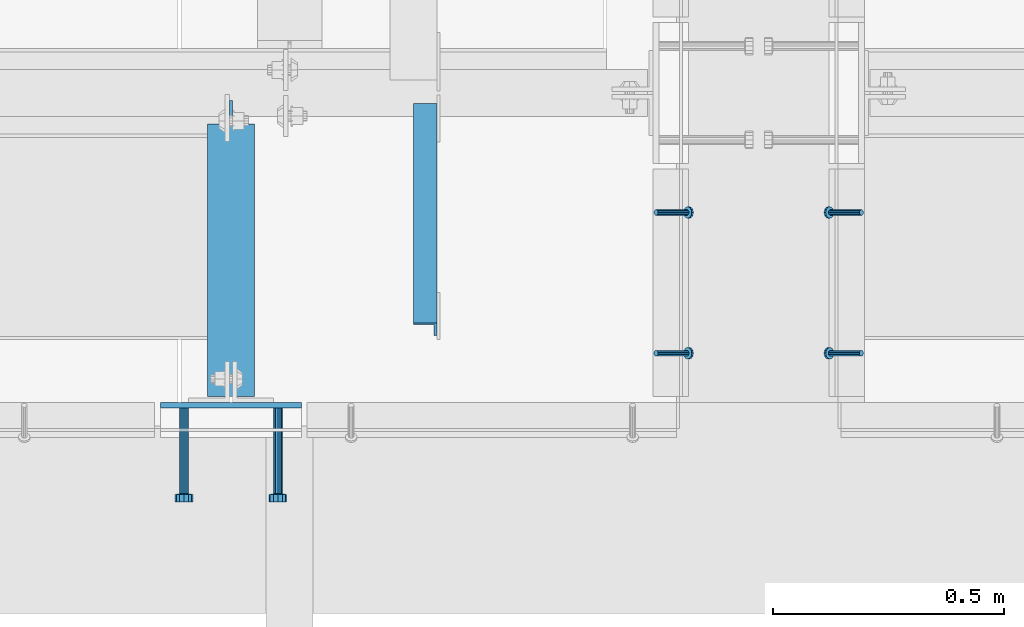
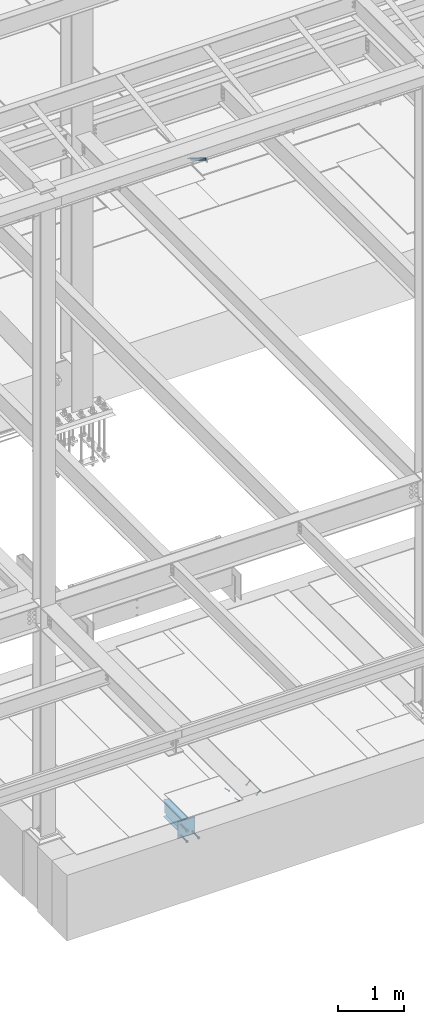
# One storey, part 2046 of 3843: 5 beams, 5 members, 5 elements without a shape of their own.
"""IFC2X3 building model written with IfcOpenShell, lengths in millimetres."""

from ifc_helpers import new_model, si_unit, frame, origin_with_axes, place, context, subcontext, project, spatial, faceted_brep, material, type_object, element, aggregate, save


model = new_model("IFC2X3")

# Units and contexts
model_context = context("Model", 3, precision=1e-05, world=origin_with_axes())
body_context = subcontext(model_context, "Body", "Model", "MODEL_VIEW")
ifc_project = project(units=[si_unit("LENGTHUNIT", "METRE", prefix="MILLI"), si_unit("AREAUNIT", "SQUARE_METRE"), si_unit("VOLUMEUNIT", "CUBIC_METRE"), si_unit("MASSUNIT", "GRAM", prefix="KILO"), si_unit("TIMEUNIT", "SECOND"), si_unit("PLANEANGLEUNIT", "RADIAN"), si_unit("SOLIDANGLEUNIT", "STERADIAN"), si_unit("THERMODYNAMICTEMPERATUREUNIT", "DEGREE_CELSIUS"), si_unit("LUMINOUSINTENSITYUNIT", "LUMEN")], contexts=[model_context])

# Site, building, storey
site_placement = place(None, origin_with_axes())
site = spatial("IfcSite", under=ifc_project, at=site_placement, CompositionType="ELEMENT")
building_placement = place(site_placement, origin_with_axes())
building = spatial("IfcBuilding", under=site, at=building_placement, Name="Undefined", CompositionType="ELEMENT")
storey_placement = place(building_placement, origin_with_axes())
storey = spatial("IfcBuildingStorey", under=building, at=storey_placement, Name="Undefined", CompositionType="ELEMENT", Elevation=0.0)

# Assembly, members
assembly_1_placement = place(storey_placement, origin_with_axes())
assembly_1 = element("IfcElementAssembly", 1, at=assembly_1_placement, inside=storey, Name="ANGLE", AssemblyPlace="NOTDEFINED", PredefinedType="RIGID_FRAME")
ifc_material_1 = material(Name="STEEL/A108")
member_type_1 = type_object("IfcMemberType", PredefinedType="NOTDEFINED")
member_1_placement = place(assembly_1_placement, frame((59404.2499975309, 14739.9375000699, 30422.8500045777), z_axis=(0.0, -1.0, 0.0), x_axis=(-0.707106781186548, 0.0, -0.707106781186548)))
member_1 = element("IfcMember", 2, at=member_1_placement, type_object=member_type_1, material=ifc_material_1, Name="HEADED STUD ANCHOR", context=body_context, shape_type="Brep", body=[
    faceted_brep([(7.27595761418343e-12, -3.18000006675175, 5.5), (0.0, -5.49999999998363, 3.1800000667572), (94.4879985803855, -5.50000000011278, 3.1800000667572), (94.4879985803782, -3.18000006687362, 5.5), (0.0, -6.3499999046162, 0.0), (94.4879985803855, -6.34999990474535, 0.0), (0.0, -5.49999999998363, -3.1800000667572), (94.4879985803855, -5.50000000011278, -3.1800000667572), (7.27595761418343e-12, -3.18000006675175, -5.5), (94.4879985803782, -3.18000006687362, -5.5), (7.27595761418343e-12, -1.81898940354586e-12, -6.34999990463257), (94.4879985803782, -1.20053300634027e-10, -6.34999990463257), (0.0, 3.18000006675175, -5.5), (94.4879985803709, 3.18000006663351, -5.5), (7.27595761418343e-12, 5.49999999998363, -3.1800000667572), (94.4879985803709, 5.49999999987267, -3.1800000667572), (7.27595761418343e-12, 6.3499999046162, 0.0), (94.4879985803673, 6.34999990450706, 0.0), (7.27595761418343e-12, 5.49999999998363, 3.1800000667572), (94.4879985803709, 5.49999999987267, 3.1800000667572), (0.0, 3.18000006675175, 5.5), (94.4879985803709, 3.18000006663351, 5.5), (7.27595761418343e-12, -1.81898940354586e-12, 6.34999990463257), (94.4879985803782, -1.20053300634027e-10, 6.34999990463257), (96.5199985498621, -10.9899997712273, 6.34999990463257), (96.5199985498548, -6.34000015270249, 10.9899997711182), (96.5199985498621, -12.6999998093743, 0.0), (96.5199985498621, -10.9899997712273, -6.34999990463257), (96.5199985498548, -6.34000015270249, -10.9899997711182), (96.5199985498475, -1.21872290037572e-10, -12.6899995803833), (96.5199985498402, 6.34000015245874, -10.9899997711182), (96.519998549833, 10.9899997709817, -6.34999990463257), (96.519998549833, 12.6999998091305, 0.0), (96.519998549833, 10.9899997709817, 6.34999990463257), (96.5199985498402, 6.34000015245874, 10.9899997711182), (96.5199985498475, -1.21872290037572e-10, 12.6899995803833), (101.599998473539, -10.9899997712328, 6.34999990463257), (101.599998473532, -6.34000015270976, 10.9899997711182), (101.599998473539, -12.6999998093797, 0.0), (101.599998473539, -10.9899997712328, -6.34999990463257), (101.599998473532, -6.34000015270976, -10.9899997711182), (101.599998473524, -1.29148247651756e-10, -12.6899995803833), (101.599998473517, 6.34000015245329, -10.9899997711182), (101.59999847351, 10.9899997709763, -6.34999990463257), (101.599998473503, 12.6999998091196, 0.0), (101.59999847351, 10.9899997709763, 6.34999990463257), (101.599998473517, 6.34000015245329, 10.9899997711182), (101.599998473524, -1.29148247651756e-10, 12.6899995803833)], [[[0, 1, 2, 3]], [[1, 4, 5, 2]], [[4, 6, 7, 5]], [[6, 8, 9, 7]], [[8, 10, 11, 9]], [[10, 12, 13, 11]], [[12, 14, 15, 13]], [[14, 16, 17, 15]], [[16, 18, 19, 17]], [[18, 20, 21, 19]], [[20, 22, 23, 21]], [[22, 0, 3, 23]], [[22, 20, 18, 16, 14, 12, 10, 8, 6, 4, 1, 0]], [[3, 2, 24, 25]], [[2, 5, 26, 24]], [[5, 7, 27, 26]], [[7, 9, 28, 27]], [[9, 11, 29, 28]], [[11, 13, 30, 29]], [[13, 15, 31, 30]], [[15, 17, 32, 31]], [[17, 19, 33, 32]], [[19, 21, 34, 33]], [[21, 23, 35, 34]], [[23, 3, 25, 35]], [[25, 24, 36, 37]], [[24, 26, 38, 36]], [[26, 27, 39, 38]], [[27, 28, 40, 39]], [[28, 29, 41, 40]], [[29, 30, 42, 41]], [[30, 31, 43, 42]], [[31, 32, 44, 43]], [[32, 33, 45, 44]], [[33, 34, 46, 45]], [[34, 35, 47, 46]], [[35, 25, 37, 47]], [[38, 39, 40, 41, 42, 43, 44, 45, 46, 47, 37, 36]]]),
])
member_2_placement = place(assembly_1_placement, frame((59404.2499975309, 14435.1375000699, 30422.8500045777), z_axis=(0.0, -1.0, 0.0), x_axis=(-0.707106781186548, 0.0, -0.707106781186548)))
member_2 = element("IfcMember", 3, at=member_2_placement, type_object=member_type_1, material=ifc_material_1, Name="HEADED STUD ANCHOR", context=body_context, shape_type="Brep", body=[
    faceted_brep([(7.27595761418343e-12, -3.18000006675175, 5.5), (0.0, -5.49999999998363, 3.1800000667572), (94.4879985803855, -5.50000000011278, 3.1800000667572), (94.4879985803782, -3.18000006687362, 5.5), (0.0, -6.3499999046162, 0.0), (94.4879985803855, -6.34999990474535, 0.0), (0.0, -5.49999999998363, -3.1800000667572), (94.4879985803855, -5.50000000011278, -3.1800000667572), (7.27595761418343e-12, -3.18000006675175, -5.5), (94.4879985803782, -3.18000006687362, -5.5), (7.27595761418343e-12, -1.81898940354586e-12, -6.34999990463257), (94.4879985803782, -1.20053300634027e-10, -6.34999990463257), (0.0, 3.18000006675175, -5.5), (94.4879985803709, 3.18000006663351, -5.5), (7.27595761418343e-12, 5.49999999998363, -3.1800000667572), (94.4879985803709, 5.49999999987267, -3.1800000667572), (7.27595761418343e-12, 6.3499999046162, 0.0), (94.4879985803673, 6.34999990450706, 0.0), (7.27595761418343e-12, 5.49999999998363, 3.1800000667572), (94.4879985803709, 5.49999999987267, 3.1800000667572), (0.0, 3.18000006675175, 5.5), (94.4879985803709, 3.18000006663351, 5.5), (7.27595761418343e-12, -1.81898940354586e-12, 6.34999990463257), (94.4879985803782, -1.20053300634027e-10, 6.34999990463257), (96.5199985498621, -10.9899997712273, 6.34999990463257), (96.5199985498548, -6.34000015270249, 10.9899997711182), (96.5199985498621, -12.6999998093743, 0.0), (96.5199985498621, -10.9899997712273, -6.34999990463257), (96.5199985498548, -6.34000015270249, -10.9899997711182), (96.5199985498475, -1.21872290037572e-10, -12.6899995803833), (96.5199985498402, 6.34000015245874, -10.9899997711182), (96.519998549833, 10.9899997709817, -6.34999990463257), (96.519998549833, 12.6999998091305, 0.0), (96.519998549833, 10.9899997709817, 6.34999990463257), (96.5199985498402, 6.34000015245874, 10.9899997711182), (96.5199985498475, -1.21872290037572e-10, 12.6899995803833), (101.599998473539, -10.9899997712328, 6.34999990463257), (101.599998473532, -6.34000015270976, 10.9899997711182), (101.599998473539, -12.6999998093797, 0.0), (101.599998473539, -10.9899997712328, -6.34999990463257), (101.599998473532, -6.34000015270976, -10.9899997711182), (101.599998473524, -1.29148247651756e-10, -12.6899995803833), (101.599998473517, 6.34000015245329, -10.9899997711182), (101.59999847351, 10.9899997709763, -6.34999990463257), (101.599998473503, 12.6999998091196, 0.0), (101.59999847351, 10.9899997709763, 6.34999990463257), (101.599998473517, 6.34000015245329, 10.9899997711182), (101.599998473524, -1.29148247651756e-10, 12.6899995803833)], [[[0, 1, 2, 3]], [[1, 4, 5, 2]], [[4, 6, 7, 5]], [[6, 8, 9, 7]], [[8, 10, 11, 9]], [[10, 12, 13, 11]], [[12, 14, 15, 13]], [[14, 16, 17, 15]], [[16, 18, 19, 17]], [[18, 20, 21, 19]], [[20, 22, 23, 21]], [[22, 0, 3, 23]], [[22, 20, 18, 16, 14, 12, 10, 8, 6, 4, 1, 0]], [[3, 2, 24, 25]], [[2, 5, 26, 24]], [[5, 7, 27, 26]], [[7, 9, 28, 27]], [[9, 11, 29, 28]], [[11, 13, 30, 29]], [[13, 15, 31, 30]], [[15, 17, 32, 31]], [[17, 19, 33, 32]], [[19, 21, 34, 33]], [[21, 23, 35, 34]], [[23, 3, 25, 35]], [[25, 24, 36, 37]], [[24, 26, 38, 36]], [[26, 27, 39, 38]], [[27, 28, 40, 39]], [[28, 29, 41, 40]], [[29, 30, 42, 41]], [[30, 31, 43, 42]], [[31, 32, 44, 43]], [[32, 33, 45, 44]], [[33, 34, 46, 45]], [[34, 35, 47, 46]], [[35, 25, 37, 47]], [[38, 39, 40, 41, 42, 43, 44, 45, 46, 47, 37, 36]]]),
])
aggregate(assembly_1, [member_1, member_2])

assembly_2_placement = place(storey_placement, origin_with_axes())
assembly_2 = element("IfcElementAssembly", 4, at=assembly_2_placement, inside=storey, Name="ANGLE", AssemblyPlace="NOTDEFINED", PredefinedType="RIGID_FRAME")
member_3_placement = place(assembly_2_placement, frame((58959.7500022606, 14739.9375000317, 30422.8500045777), z_axis=(0.0, 1.0, 0.0), x_axis=(0.707106781186548, 0.0, -0.707106781186548)))
member_3 = element("IfcMember", 5, at=member_3_placement, type_object=member_type_1, material=ifc_material_1, Name="HEADED STUD ANCHOR", context=body_context, shape_type="Brep", body=[
    faceted_brep([(7.27595761418343e-12, -3.18000006675175, 5.5), (0.0, -5.49999999998363, 3.1800000667572), (94.4879985803855, -5.50000000011278, 3.1800000667572), (94.4879985803782, -3.18000006687362, 5.5), (0.0, -6.3499999046162, 0.0), (94.4879985803855, -6.34999990474535, 0.0), (0.0, -5.49999999998363, -3.1800000667572), (94.4879985803855, -5.50000000011278, -3.1800000667572), (7.27595761418343e-12, -3.18000006675175, -5.5), (94.4879985803782, -3.18000006687362, -5.5), (7.27595761418343e-12, -1.81898940354586e-12, -6.34999990463257), (94.4879985803782, -1.20053300634027e-10, -6.34999990463257), (0.0, 3.18000006675175, -5.5), (94.4879985803709, 3.18000006663351, -5.5), (7.27595761418343e-12, 5.49999999998363, -3.1800000667572), (94.4879985803709, 5.49999999987267, -3.1800000667572), (7.27595761418343e-12, 6.3499999046162, 0.0), (94.4879985803673, 6.34999990450706, 0.0), (7.27595761418343e-12, 5.49999999998363, 3.1800000667572), (94.4879985803709, 5.49999999987267, 3.1800000667572), (0.0, 3.18000006675175, 5.5), (94.4879985803709, 3.18000006663351, 5.5), (7.27595761418343e-12, -1.81898940354586e-12, 6.34999990463257), (94.4879985803782, -1.20053300634027e-10, 6.34999990463257), (96.5199985498621, -10.9899997712273, 6.34999990463257), (96.5199985498548, -6.34000015270249, 10.9899997711182), (96.5199985498621, -12.6999998093743, 0.0), (96.5199985498621, -10.9899997712273, -6.34999990463257), (96.5199985498548, -6.34000015270249, -10.9899997711182), (96.5199985498475, -1.21872290037572e-10, -12.6899995803833), (96.5199985498402, 6.34000015245874, -10.9899997711182), (96.519998549833, 10.9899997709817, -6.34999990463257), (96.519998549833, 12.6999998091305, 0.0), (96.519998549833, 10.9899997709817, 6.34999990463257), (96.5199985498402, 6.34000015245874, 10.9899997711182), (96.5199985498475, -1.21872290037572e-10, 12.6899995803833), (101.599998473539, -10.9899997712328, 6.34999990463257), (101.599998473532, -6.34000015270976, 10.9899997711182), (101.599998473539, -12.6999998093797, 0.0), (101.599998473539, -10.9899997712328, -6.34999990463257), (101.599998473532, -6.34000015270976, -10.9899997711182), (101.599998473524, -1.29148247651756e-10, -12.6899995803833), (101.599998473517, 6.34000015245329, -10.9899997711182), (101.59999847351, 10.9899997709763, -6.34999990463257), (101.599998473503, 12.6999998091196, 0.0), (101.59999847351, 10.9899997709763, 6.34999990463257), (101.599998473517, 6.34000015245329, 10.9899997711182), (101.599998473524, -1.29148247651756e-10, 12.6899995803833)], [[[0, 1, 2, 3]], [[1, 4, 5, 2]], [[4, 6, 7, 5]], [[6, 8, 9, 7]], [[8, 10, 11, 9]], [[10, 12, 13, 11]], [[12, 14, 15, 13]], [[14, 16, 17, 15]], [[16, 18, 19, 17]], [[18, 20, 21, 19]], [[20, 22, 23, 21]], [[22, 0, 3, 23]], [[22, 20, 18, 16, 14, 12, 10, 8, 6, 4, 1, 0]], [[3, 2, 24, 25]], [[2, 5, 26, 24]], [[5, 7, 27, 26]], [[7, 9, 28, 27]], [[9, 11, 29, 28]], [[11, 13, 30, 29]], [[13, 15, 31, 30]], [[15, 17, 32, 31]], [[17, 19, 33, 32]], [[19, 21, 34, 33]], [[21, 23, 35, 34]], [[23, 3, 25, 35]], [[25, 24, 36, 37]], [[24, 26, 38, 36]], [[26, 27, 39, 38]], [[27, 28, 40, 39]], [[28, 29, 41, 40]], [[29, 30, 42, 41]], [[30, 31, 43, 42]], [[31, 32, 44, 43]], [[32, 33, 45, 44]], [[33, 34, 46, 45]], [[34, 35, 47, 46]], [[35, 25, 37, 47]], [[38, 39, 40, 41, 42, 43, 44, 45, 46, 47, 37, 36]]]),
])
member_4_placement = place(assembly_2_placement, frame((58959.7500022606, 14435.1375000317, 30422.8500045777), z_axis=(0.0, 1.0, 0.0), x_axis=(0.707106781186548, 0.0, -0.707106781186548)))
member_4 = element("IfcMember", 6, at=member_4_placement, type_object=member_type_1, material=ifc_material_1, Name="HEADED STUD ANCHOR", context=body_context, shape_type="Brep", body=[
    faceted_brep([(7.27595761418343e-12, -3.18000006675175, 5.5), (0.0, -5.49999999998363, 3.1800000667572), (94.4879985803855, -5.50000000011278, 3.1800000667572), (94.4879985803782, -3.18000006687362, 5.5), (0.0, -6.3499999046162, 0.0), (94.4879985803855, -6.34999990474535, 0.0), (0.0, -5.49999999998363, -3.1800000667572), (94.4879985803855, -5.50000000011278, -3.1800000667572), (7.27595761418343e-12, -3.18000006675175, -5.5), (94.4879985803782, -3.18000006687362, -5.5), (7.27595761418343e-12, -1.81898940354586e-12, -6.34999990463257), (94.4879985803782, -1.20053300634027e-10, -6.34999990463257), (0.0, 3.18000006675175, -5.5), (94.4879985803709, 3.18000006663351, -5.5), (7.27595761418343e-12, 5.49999999998363, -3.1800000667572), (94.4879985803709, 5.49999999987267, -3.1800000667572), (7.27595761418343e-12, 6.3499999046162, 0.0), (94.4879985803673, 6.34999990450706, 0.0), (7.27595761418343e-12, 5.49999999998363, 3.1800000667572), (94.4879985803709, 5.49999999987267, 3.1800000667572), (0.0, 3.18000006675175, 5.5), (94.4879985803709, 3.18000006663351, 5.5), (7.27595761418343e-12, -1.81898940354586e-12, 6.34999990463257), (94.4879985803782, -1.20053300634027e-10, 6.34999990463257), (96.5199985498621, -10.9899997712273, 6.34999990463257), (96.5199985498548, -6.34000015270249, 10.9899997711182), (96.5199985498621, -12.6999998093743, 0.0), (96.5199985498621, -10.9899997712273, -6.34999990463257), (96.5199985498548, -6.34000015270249, -10.9899997711182), (96.5199985498475, -1.21872290037572e-10, -12.6899995803833), (96.5199985498402, 6.34000015245874, -10.9899997711182), (96.519998549833, 10.9899997709817, -6.34999990463257), (96.519998549833, 12.6999998091305, 0.0), (96.519998549833, 10.9899997709817, 6.34999990463257), (96.5199985498402, 6.34000015245874, 10.9899997711182), (96.5199985498475, -1.21872290037572e-10, 12.6899995803833), (101.599998473539, -10.9899997712328, 6.34999990463257), (101.599998473532, -6.34000015270976, 10.9899997711182), (101.599998473539, -12.6999998093797, 0.0), (101.599998473539, -10.9899997712328, -6.34999990463257), (101.599998473532, -6.34000015270976, -10.9899997711182), (101.599998473524, -1.29148247651756e-10, -12.6899995803833), (101.599998473517, 6.34000015245329, -10.9899997711182), (101.59999847351, 10.9899997709763, -6.34999990463257), (101.599998473503, 12.6999998091196, 0.0), (101.59999847351, 10.9899997709763, 6.34999990463257), (101.599998473517, 6.34000015245329, 10.9899997711182), (101.599998473524, -1.29148247651756e-10, 12.6899995803833)], [[[0, 1, 2, 3]], [[1, 4, 5, 2]], [[4, 6, 7, 5]], [[6, 8, 9, 7]], [[8, 10, 11, 9]], [[10, 12, 13, 11]], [[12, 14, 15, 13]], [[14, 16, 17, 15]], [[16, 18, 19, 17]], [[18, 20, 21, 19]], [[20, 22, 23, 21]], [[22, 0, 3, 23]], [[22, 20, 18, 16, 14, 12, 10, 8, 6, 4, 1, 0]], [[3, 2, 24, 25]], [[2, 5, 26, 24]], [[5, 7, 27, 26]], [[7, 9, 28, 27]], [[9, 11, 29, 28]], [[11, 13, 30, 29]], [[13, 15, 31, 30]], [[15, 17, 32, 31]], [[17, 19, 33, 32]], [[19, 21, 34, 33]], [[21, 23, 35, 34]], [[23, 3, 25, 35]], [[25, 24, 36, 37]], [[24, 26, 38, 36]], [[26, 27, 39, 38]], [[27, 28, 40, 39]], [[28, 29, 41, 40]], [[29, 30, 42, 41]], [[30, 31, 43, 42]], [[31, 32, 44, 43]], [[32, 33, 45, 44]], [[33, 34, 46, 45]], [[34, 35, 47, 46]], [[35, 25, 37, 47]], [[38, 39, 40, 41, 42, 43, 44, 45, 46, 47, 37, 36]]]),
])
aggregate(assembly_2, [member_3, member_4])

# Assembly, beam
assembly_3_placement = place(storey_placement, origin_with_axes())
assembly_3 = element("IfcElementAssembly", 7, at=assembly_3_placement, inside=storey, Name="EMBED PLATE", AssemblyPlace="NOTDEFINED", PredefinedType="RIGID_FRAME")
ifc_material_2 = material(Name="STEEL/A36")
beam_type_1 = type_object("IfcBeamType", PredefinedType="NOTDEFINED")
beam_1_placement = place(assembly_3_placement, frame((58039.0, 14322.425, 30422.85), z_axis=(-1.0, 0.0, 0.0), x_axis=(0.0, 0.0, -1.0)))
beam_1 = element("IfcBeam", 8, at=beam_1_placement, type_object=beam_type_1, material=ifc_material_2, Name="EMBED PLATE", context=body_context, shape_type="Brep", body=[
    faceted_brep([(-1.0550138540566e-10, 6.34999999999854, -152.400000000664), (1.0550138540566e-10, 6.34999999999854, 152.400000000656), (304.799999999999, 6.34999999999854, 152.400000000001), (304.799999999999, 6.34999999999854, -152.400000000001), (1.0550138540566e-10, -6.34999999999854, 152.400000000656), (304.799999999999, -6.34999999999854, 152.400000000001), (-1.0550138540566e-10, -6.34999999999854, -152.400000000664), (304.799999999999, -6.34999999999854, -152.400000000001)], [[[0, 1, 2, 3]], [[1, 4, 5, 2]], [[4, 6, 7, 5]], [[6, 0, 3, 7]], [[5, 7, 3, 2]], [[6, 4, 1, 0]]]),
])

# Assembly, member
assembly_4_placement = place(storey_placement, origin_with_axes())
assembly_4 = element("IfcElementAssembly", 9, at=assembly_4_placement, inside=storey, Name="ANGLE", AssemblyPlace="NOTDEFINED", PredefinedType="RIGID_FRAME")
ifc_material_3 = material(Name="STEEL/A572-50")
member_type_2 = type_object("IfcMemberType", Name="L2X2X1/4", PredefinedType="NOTDEFINED")
member_5_placement = place(assembly_4_placement, frame((58459.6875, 14962.4615149769, 42136.6100587905), z_axis=(-1.0, 0.0, 0.0), x_axis=(0.0, -0.851012521472712, 0.5251453972917)))
member_5 = element("IfcMember", 10, at=member_5_placement, type_object=member_type_2, material=ifc_material_3, Name="ANGLE", ObjectType="L2X2X1/4", context=body_context, shape_type="Brep", body=[
    faceted_brep([(0.0, 25.4000000000015, -25.4000000000015), (0.0, 25.4000000000015, 25.4000000000015), (558.799999999297, 25.3999999986918, 25.3999999999942), (558.799999999297, 25.3999999986918, -25.3999999999942), (0.0, 19.0500000000029, 25.4000000000015), (558.799999999297, 19.049999998686, 25.3999999999942), (0.0, 19.0500000000029, -19.0499999999993), (558.799999999297, 19.049999998686, -19.0500000000029), (0.0, -25.4000000000015, -19.0499999999993), (558.799999999281, -25.4000000013912, -19.0500000000029), (0.0, -25.4000000000015, -25.4000000000015), (558.799999999281, -25.4000000013912, -25.3999999999942)], [[[0, 1, 2, 3]], [[1, 4, 5, 2]], [[4, 6, 7, 5]], [[6, 8, 9, 7]], [[8, 10, 11, 9]], [[10, 0, 3, 11]], [[5, 7, 9, 11, 3, 2]], [[10, 8, 6, 4, 1, 0]]]),
])
aggregate(assembly_4, [member_5])

# Beam
beam_type_2 = type_object("IfcBeamType", PredefinedType="NOTDEFINED")
beam_2_placement = place(assembly_3_placement, frame((58140.6, 14316.075, 30168.85), z_axis=(1.0, 0.0, 0.0), x_axis=(0.0, -1.0, 0.0)))
beam_2 = element("IfcBeam", 11, at=beam_2_placement, type_object=beam_type_2, material=ifc_material_1, Name="HEADED STUD ANCHOR", context=body_context, shape_type="Brep", body=[
    faceted_brep([(0.0, -9.52000045776367, 0.0), (0.0, -8.25, -4.76000022888184), (184.912000000004, -8.25, -4.76000022888184), (184.912000000004, -9.52000045776367, 0.0), (0.0, -4.76000022888184, -8.25), (184.912000000004, -4.76000022888184, -8.25), (0.0, 0.0, -9.52000045776367), (184.912000000004, 0.0, -9.52000045776367), (0.0, 4.76000022888184, -8.25), (184.912000000004, 4.76000022888184, -8.25), (0.0, 8.25, -4.76000022888184), (184.912000000004, 8.25, -4.76000022888184), (0.0, 9.52000045776367, 0.0), (184.912000000004, 9.52000045776367, 0.0), (0.0, 8.25, 4.76000022888184), (184.912000000004, 8.25, 4.76000022888184), (0.0, 4.76000022888184, 8.25), (184.912000000004, 4.76000022888184, 8.25), (0.0, 0.0, 9.52000045776367), (184.912000000004, 0.0, 9.52000045776367), (0.0, -4.76000022888184, 8.25), (184.912000000004, -4.76000022888184, 8.25), (0.0, -8.25, 4.76000022888184), (184.912000000004, -8.25, 4.76000022888184), (186.944000000003, -16.5, -9.52000045776367), (186.944000000003, -19.0499992370605, 0.0), (186.944000000003, -9.52000045776367, -16.5), (186.944000000003, 0.0, -19.0499992370605), (186.944000000003, 9.52000045776367, -16.5), (186.944000000003, 16.5, -9.52000045776367), (186.944000000003, 19.0499992370605, 0.0), (186.944000000003, 16.5, 9.52000045776367), (186.944000000003, 9.52000045776367, 16.5), (186.944000000003, 0.0, 19.0499992370605), (186.944000000003, -9.52000045776367, 16.5), (186.944000000003, -16.5, 9.52000045776367), (203.199999999997, -16.5, -9.52000045776367), (203.199999999997, -19.0499992370605, 0.0), (203.199999999997, -9.52000045776367, -16.5), (203.199999999997, 0.0, -19.0499992370605), (203.199999999997, 9.52000045776367, -16.5), (203.199999999997, 16.5, -9.52000045776367), (203.199999999997, 19.0499992370605, 0.0), (203.199999999997, 16.5, 9.52000045776367), (203.199999999997, 9.52000045776367, 16.5), (203.199999999997, 0.0, 19.0499992370605), (203.199999999997, -9.52000045776367, 16.5), (203.199999999997, -16.5, 9.52000045776367)], [[[0, 1, 2, 3]], [[1, 4, 5, 2]], [[4, 6, 7, 5]], [[6, 8, 9, 7]], [[8, 10, 11, 9]], [[10, 12, 13, 11]], [[12, 14, 15, 13]], [[14, 16, 17, 15]], [[16, 18, 19, 17]], [[18, 20, 21, 19]], [[20, 22, 23, 21]], [[22, 0, 3, 23]], [[22, 20, 18, 16, 14, 12, 10, 8, 6, 4, 1, 0]], [[3, 2, 24, 25]], [[2, 5, 26, 24]], [[5, 7, 27, 26]], [[7, 9, 28, 27]], [[9, 11, 29, 28]], [[11, 13, 30, 29]], [[13, 15, 31, 30]], [[15, 17, 32, 31]], [[17, 19, 33, 32]], [[19, 21, 34, 33]], [[21, 23, 35, 34]], [[23, 3, 25, 35]], [[25, 24, 36, 37]], [[24, 26, 38, 36]], [[26, 27, 39, 38]], [[27, 28, 40, 39]], [[28, 29, 41, 40]], [[29, 30, 42, 41]], [[30, 31, 43, 42]], [[31, 32, 44, 43]], [[32, 33, 45, 44]], [[33, 34, 46, 45]], [[34, 35, 47, 46]], [[35, 25, 37, 47]], [[38, 39, 40, 41, 42, 43, 44, 45, 46, 47, 37, 36]]]),
])

beam_3_placement = place(assembly_3_placement, frame((57937.4, 14316.075, 30372.05), z_axis=(1.0, 0.0, 0.0), x_axis=(0.0, -1.0, 0.0)))
beam_3 = element("IfcBeam", 12, at=beam_3_placement, type_object=beam_type_2, material=ifc_material_2, Name="PLATE", context=body_context, shape_type="Brep", body=[
    faceted_brep([(0.0, -9.52000045776367, 0.0), (0.0, -8.25, -4.76000022888184), (184.912000000004, -8.25, -4.76000022888184), (184.912000000004, -9.52000045776367, 0.0), (0.0, -4.76000022888184, -8.25), (184.912000000004, -4.76000022888184, -8.25), (0.0, 0.0, -9.52000045776367), (184.912000000004, 0.0, -9.52000045776367), (0.0, 4.76000022888184, -8.25), (184.912000000004, 4.76000022888184, -8.25), (0.0, 8.25, -4.76000022888184), (184.912000000004, 8.25, -4.76000022888184), (0.0, 9.52000045776367, 0.0), (184.912000000004, 9.52000045776367, 0.0), (0.0, 8.25, 4.76000022888184), (184.912000000004, 8.25, 4.76000022888184), (0.0, 4.76000022888184, 8.25), (184.912000000004, 4.76000022888184, 8.25), (0.0, 0.0, 9.52000045776367), (184.912000000004, 0.0, 9.52000045776367), (0.0, -4.76000022888184, 8.25), (184.912000000004, -4.76000022888184, 8.25), (0.0, -8.25, 4.76000022888184), (184.912000000004, -8.25, 4.76000022888184), (186.944000000003, -16.5, -9.52000045776367), (186.944000000003, -19.0499992370605, 0.0), (186.944000000003, -9.52000045776367, -16.5), (186.944000000003, 0.0, -19.0499992370605), (186.944000000003, 9.52000045776367, -16.5), (186.944000000003, 16.5, -9.52000045776367), (186.944000000003, 19.0499992370605, 0.0), (186.944000000003, 16.5, 9.52000045776367), (186.944000000003, 9.52000045776367, 16.5), (186.944000000003, 0.0, 19.0499992370605), (186.944000000003, -9.52000045776367, 16.5), (186.944000000003, -16.5, 9.52000045776367), (203.199999999997, -16.5, -9.52000045776367), (203.199999999997, -19.0499992370605, 0.0), (203.199999999997, -9.52000045776367, -16.5), (203.199999999997, 0.0, -19.0499992370605), (203.199999999997, 9.52000045776367, -16.5), (203.199999999997, 16.5, -9.52000045776367), (203.199999999997, 19.0499992370605, 0.0), (203.199999999997, 16.5, 9.52000045776367), (203.199999999997, 9.52000045776367, 16.5), (203.199999999997, 0.0, 19.0499992370605), (203.199999999997, -9.52000045776367, 16.5), (203.199999999997, -16.5, 9.52000045776367)], [[[0, 1, 2, 3]], [[1, 4, 5, 2]], [[4, 6, 7, 5]], [[6, 8, 9, 7]], [[8, 10, 11, 9]], [[10, 12, 13, 11]], [[12, 14, 15, 13]], [[14, 16, 17, 15]], [[16, 18, 19, 17]], [[18, 20, 21, 19]], [[20, 22, 23, 21]], [[22, 0, 3, 23]], [[22, 20, 18, 16, 14, 12, 10, 8, 6, 4, 1, 0]], [[3, 2, 24, 25]], [[2, 5, 26, 24]], [[5, 7, 27, 26]], [[7, 9, 28, 27]], [[9, 11, 29, 28]], [[11, 13, 30, 29]], [[13, 15, 31, 30]], [[15, 17, 32, 31]], [[17, 19, 33, 32]], [[19, 21, 34, 33]], [[21, 23, 35, 34]], [[23, 3, 25, 35]], [[25, 24, 36, 37]], [[24, 26, 38, 36]], [[26, 27, 39, 38]], [[27, 28, 40, 39]], [[28, 29, 41, 40]], [[29, 30, 42, 41]], [[30, 31, 43, 42]], [[31, 32, 44, 43]], [[32, 33, 45, 44]], [[33, 34, 46, 45]], [[34, 35, 47, 46]], [[35, 25, 37, 47]], [[38, 39, 40, 41, 42, 43, 44, 45, 46, 47, 37, 36]]]),
])

beam_4_placement = place(assembly_3_placement, frame((57937.4, 14316.075, 30168.85), z_axis=(1.0, 0.0, 0.0), x_axis=(0.0, -1.0, 0.0)))
beam_4 = element("IfcBeam", 13, at=beam_4_placement, type_object=beam_type_2, material=ifc_material_1, Name="HEADED STUD ANCHOR", context=body_context, shape_type="Brep", body=[
    faceted_brep([(0.0, -9.52000045776367, 0.0), (0.0, -8.25, -4.76000022888184), (184.912000000004, -8.25, -4.76000022888184), (184.912000000004, -9.52000045776367, 0.0), (0.0, -4.76000022888184, -8.25), (184.912000000004, -4.76000022888184, -8.25), (0.0, 0.0, -9.52000045776367), (184.912000000004, 0.0, -9.52000045776367), (0.0, 4.76000022888184, -8.25), (184.912000000004, 4.76000022888184, -8.25), (0.0, 8.25, -4.76000022888184), (184.912000000004, 8.25, -4.76000022888184), (0.0, 9.52000045776367, 0.0), (184.912000000004, 9.52000045776367, 0.0), (0.0, 8.25, 4.76000022888184), (184.912000000004, 8.25, 4.76000022888184), (0.0, 4.76000022888184, 8.25), (184.912000000004, 4.76000022888184, 8.25), (0.0, 0.0, 9.52000045776367), (184.912000000004, 0.0, 9.52000045776367), (0.0, -4.76000022888184, 8.25), (184.912000000004, -4.76000022888184, 8.25), (0.0, -8.25, 4.76000022888184), (184.912000000004, -8.25, 4.76000022888184), (186.944000000003, -16.5, -9.52000045776367), (186.944000000003, -19.0499992370605, 0.0), (186.944000000003, -9.52000045776367, -16.5), (186.944000000003, 0.0, -19.0499992370605), (186.944000000003, 9.52000045776367, -16.5), (186.944000000003, 16.5, -9.52000045776367), (186.944000000003, 19.0499992370605, 0.0), (186.944000000003, 16.5, 9.52000045776367), (186.944000000003, 9.52000045776367, 16.5), (186.944000000003, 0.0, 19.0499992370605), (186.944000000003, -9.52000045776367, 16.5), (186.944000000003, -16.5, 9.52000045776367), (203.199999999997, -16.5, -9.52000045776367), (203.199999999997, -19.0499992370605, 0.0), (203.199999999997, -9.52000045776367, -16.5), (203.199999999997, 0.0, -19.0499992370605), (203.199999999997, 9.52000045776367, -16.5), (203.199999999997, 16.5, -9.52000045776367), (203.199999999997, 19.0499992370605, 0.0), (203.199999999997, 16.5, 9.52000045776367), (203.199999999997, 9.52000045776367, 16.5), (203.199999999997, 0.0, 19.0499992370605), (203.199999999997, -9.52000045776367, 16.5), (203.199999999997, -16.5, 9.52000045776367)], [[[0, 1, 2, 3]], [[1, 4, 5, 2]], [[4, 6, 7, 5]], [[6, 8, 9, 7]], [[8, 10, 11, 9]], [[10, 12, 13, 11]], [[12, 14, 15, 13]], [[14, 16, 17, 15]], [[16, 18, 19, 17]], [[18, 20, 21, 19]], [[20, 22, 23, 21]], [[22, 0, 3, 23]], [[22, 20, 18, 16, 14, 12, 10, 8, 6, 4, 1, 0]], [[3, 2, 24, 25]], [[2, 5, 26, 24]], [[5, 7, 27, 26]], [[7, 9, 28, 27]], [[9, 11, 29, 28]], [[11, 13, 30, 29]], [[13, 15, 31, 30]], [[15, 17, 32, 31]], [[17, 19, 33, 32]], [[19, 21, 34, 33]], [[21, 23, 35, 34]], [[23, 3, 25, 35]], [[25, 24, 36, 37]], [[24, 26, 38, 36]], [[26, 27, 39, 38]], [[27, 28, 40, 39]], [[28, 29, 41, 40]], [[29, 30, 42, 41]], [[30, 31, 43, 42]], [[31, 32, 44, 43]], [[32, 33, 45, 44]], [[33, 34, 46, 45]], [[34, 35, 47, 46]], [[35, 25, 37, 47]], [[38, 39, 40, 41, 42, 43, 44, 45, 46, 47, 37, 36]]]),
])

aggregate(assembly_3, [beam_2, beam_3, beam_4, beam_1])

# Assembly, beam
assembly_5_placement = place(storey_placement, origin_with_axes())
assembly_5 = element("IfcElementAssembly", 14, at=assembly_5_placement, inside=storey, Name="BEAM", AssemblyPlace="NOTDEFINED", PredefinedType="RIGID_FRAME")
ifc_material_4 = material(Name="STEEL/A992")
beam_type_3 = type_object("IfcBeamType", Name="W12X16", PredefinedType="NOTDEFINED")
beam_5_placement = place(assembly_5_placement, frame((58039.0, 14328.775, 30276.8), z_axis=(0.0, 0.0, 1.0), x_axis=(0.0, 1.0, 0.0)))
beam_5 = element("IfcBeam", 15, at=beam_5_placement, type_object=beam_type_3, material=ifc_material_4, Name="BEAM", ObjectType="W12X16", context=body_context, shape_type="Brep", body=[
    faceted_brep([(603.250000000002, -3.17500000000291, -146.049999999999), (603.250000000002, -50.8000000000029, -146.049999999999), (603.250000000002, -50.8000000000029, -152.400000000001), (603.250000000002, 50.8000000000029, -152.400000000001), (603.250000000002, 50.8000000000029, -146.049999999999), (603.250000000002, 3.17500000000291, -146.049999999999), (603.250000000002, 3.17500000000291, -139.699999809265), (603.250000000002, -3.17500000000291, -139.699999809265), (604.216729922589, 3.17500000000291, -134.839920291219), (604.216729922589, -3.17500000000291, -134.839920291219), (606.969743823067, 3.17500000000291, -130.719743823065), (606.969743823067, -3.17500000000291, -130.719743823065), (611.089920291221, 3.17500000000291, -127.966729922588), (611.089920291221, -3.17500000000291, -127.966729922588), (615.949999809267, 3.17500000000291, -127.0), (615.949999809267, -3.17500000000291, -127.0), (654.049999999999, -3.17500000000291, -127.0), (654.049999999999, 3.17500000000291, -127.0), (12.7000000064072, 3.17500000014843, 146.04999999977), (12.7000030517593, 50.7999999999993, 146.049999999999), (603.249999999991, 50.8000000000029, 146.049999999999), (603.249999999991, 3.17500000000291, 146.049999999999), (12.7000030517593, -50.7999999999993, -152.400000000001), (12.7000030517593, -50.7999999999993, -146.049999999999), (12.7000000064072, -3.17500000016298, -146.049999999763), (12.7000000064072, -3.17499999987194, 146.049999999777), (12.7000030517593, -50.7999999999993, 146.049999999999), (12.7000030517593, -50.7999999999993, 152.400000000001), (12.7000030517593, 50.7999999999993, 152.400000000001), (12.7000000064072, 3.17499999985739, -146.049999999763), (12.7000030517593, 50.7999999999993, -146.049999999999), (12.7000030517593, 50.7999999999993, -152.400000000001), (603.249999999991, -3.17500000000291, 146.049999999999), (603.249999999991, -50.8000000000029, 146.049999999999), (603.249999999991, -50.8000000000029, 152.400000000001), (603.249999999991, 50.8000000000029, 152.400000000001), (603.249999999991, -3.17500000000291, 139.699999809265), (603.249999999991, 3.17500000000291, 139.699999809265), (604.216729922578, -3.17500000000291, 134.839920291219), (604.216729922578, 3.17500000000291, 134.839920291219), (606.969743823056, -3.17500000000291, 130.719743823065), (606.969743823056, 3.17500000000291, 130.719743823065), (611.08992029121, -3.17500000000291, 127.966729922588), (611.08992029121, 3.17500000000291, 127.966729922588), (615.949999809256, -3.17500000000291, 127.0), (615.949999809256, 3.17500000000291, 127.0), (654.049999999999, -3.17500000000291, 127.0), (654.049999999999, 3.17500000000291, 127.0), (654.049999999999, 3.17500000000291, -116.299999999999), (654.049999999999, 3.17500000000291, 114.299999999999)], [[[0, 1, 2, 3, 4, 5, 6, 7]], [[7, 6, 8, 9]], [[9, 8, 10, 11]], [[11, 10, 12, 13]], [[13, 12, 14, 15]], [[16, 15, 14, 17]], [[18, 19, 20, 21]], [[22, 23, 24, 25, 26, 27, 28, 19, 18, 29, 30, 31]], [[26, 25, 32, 33]], [[27, 26, 33, 34]], [[28, 27, 34, 35]], [[19, 28, 35, 20]], [[34, 33, 32, 36, 37, 21, 20, 35]], [[38, 39, 37, 36]], [[40, 41, 39, 38]], [[42, 43, 41, 40]], [[44, 45, 43, 42]], [[46, 47, 45, 44]], [[48, 49, 47, 46, 16, 17]], [[12, 10, 8, 6, 5, 29, 18, 21, 37, 39, 41, 43, 45, 47, 49, 48, 17, 14]], [[30, 29, 5, 4]], [[31, 30, 4, 3]], [[22, 31, 3, 2]], [[23, 22, 2, 1]], [[24, 23, 1, 0]], [[46, 44, 42, 40, 38, 36, 32, 25, 24, 0, 7, 9, 11, 13, 15, 16]]]),
])
aggregate(assembly_5, [beam_5])

save(model, "model.ifc")
